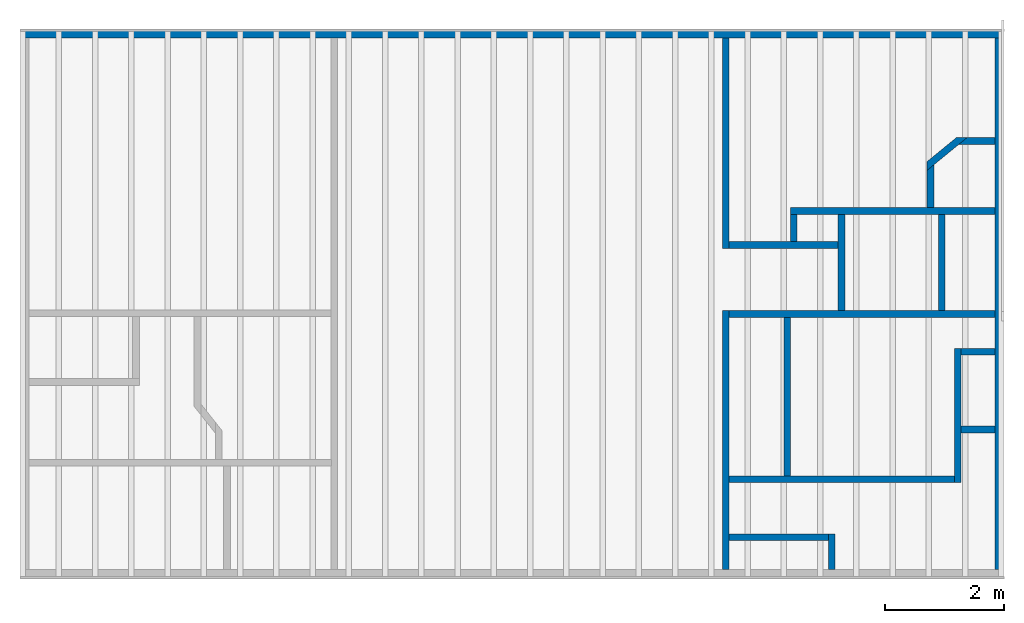
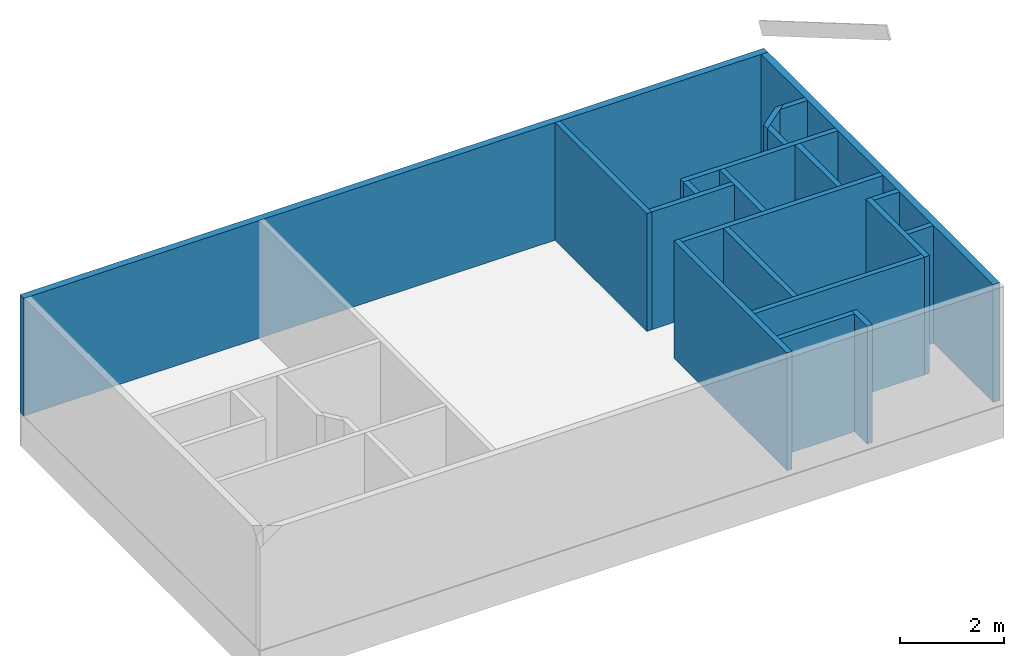
# One storey, part 2 of 2: 20 walls.
"""IFC4 building model written with IfcOpenShell, lengths in inches."""

from ifc_helpers import new_model, entity, si_unit, converted_unit, frame, origin_with_axes, origin_2d_with_axis, place, context, subcontext, project, spatial, indexed_curve, outline, extrude, clip, halfspace, material, layer, layer_set, layer_usage, type_object, element, save


model = new_model("IFC4")

# Units and contexts
model_context = context("Model", 3, precision=1e-05, world=origin_with_axes())
plan_context = context("Plan", 2, precision=1e-05, world=origin_2d_with_axis())
body_context = subcontext(model_context, "Body", "Model", "MODEL_VIEW")
ifc_project = project(units=[converted_unit("PLANEANGLEUNIT", "degree", entity("IfcReal", 0.0174532925199433), si_unit("PLANEANGLEUNIT", "RADIAN"), dimensions=[0, 0, 0, 0, 0, 0, 0]), converted_unit("AREAUNIT", "square inch", entity("IfcReal", 0.0006452), si_unit("AREAUNIT", "SQUARE_METRE"), dimensions=[2, 0, 0, 0, 0, 0, 0]), converted_unit("LENGTHUNIT", "inch", entity("IfcReal", 0.0254), si_unit("LENGTHUNIT", "METRE"), dimensions=[1, 0, 0, 0, 0, 0, 0]), converted_unit("VOLUMEUNIT", "cubic inch", entity("IfcReal", 1.639e-05), si_unit("VOLUMEUNIT", "CUBIC_METRE"), dimensions=[3, 0, 0, 0, 0, 0, 0])], contexts=[model_context, plan_context])

# Site, building, storey
site_placement = place(None, origin_with_axes())
site = spatial("IfcSite", under=ifc_project, at=site_placement)
building_placement = place(site_placement, frame((0.0, 0.0, 109.012492998378), z_axis=(0.0, 0.0, 1.0), x_axis=(1.0, 0.0, 0.0)))
building = spatial("IfcBuilding", under=site, at=building_placement, Name="Building")
storey_placement = place(building_placement, frame((0.0, 0.0, -109.012492998378), z_axis=(0.0, 0.0, 1.0), x_axis=(1.0, 0.0, 0.0)))
storey = spatial("IfcBuildingStorey", under=building, at=storey_placement, Name="1st Floor")

# Walls
ifc_material = material(Name="Default")
ifc_layer_1 = layer(ifc_material, 6.0, Name="6in")
ifc_layer_set_1 = layer_set([ifc_layer_1], Name="6in")
ifc_layer_usage_1 = layer_usage(ifc_layer_set_1, "AXIS2", "POSITIVE", 0.0)
wall_type_1 = type_object("IfcWallType", Name="6in wall", PredefinedType="ELEMENTEDWALL", material=ifc_layer_set_1)
wall_1_placement = place(storey_placement, frame((-18.4998667146277, 0.0, 0.0), z_axis=(0.0, 0.0, 1.0), x_axis=(1.0, 0.0, 0.0)))
element("IfcWall", 1, at=wall_1_placement, inside=storey, type_object=wall_type_1, material=ifc_layer_usage_1, Name="Wall", PredefinedType="NOTDEFINED", context=body_context, shape_type="SweptSolid", body=[
    extrude(outline(indexed_curve([(0.0, 0.0), (0.0, 6.0), (651.499838134765, 6.0), (651.499838134765, 0.0), (0.0, 0.0)], self_intersect=False)), origin_with_axes(), (0.0, 0.0, 1.0), 109.012496948242),
])
ifc_layer_usage_2 = layer_usage(ifc_layer_set_1, "AXIS2", "POSITIVE", 0.0)
wall_2_placement = place(storey_placement, frame((632.999825665331, -351.879014743595, 0.0), z_axis=(0.0, 0.0, 1.0), x_axis=(5.52335052361741e-07, 1.0, 0.0)))
element("IfcWall", 2, at=wall_2_placement, inside=storey, type_object=wall_type_1, material=ifc_layer_usage_2, Name="Wall", PredefinedType="NOTDEFINED", context=body_context, shape_type="SweptSolid", body=[
    extrude(outline(indexed_curve([(0.0, 0.0), (0.0, 6.0), (351.879018305891, 6.0), (351.879018305891, 0.0), (0.0, 0.0)], self_intersect=False)), origin_with_axes(), (0.0, 0.0, 1.0), 109.012496948242),
])
ifc_layer_2 = layer(ifc_material, 4.5, Name="4.5 wall")
ifc_layer_set_2 = layer_set([ifc_layer_2], Name="4.5 wall")
ifc_layer_usage_3 = layer_usage(ifc_layer_set_2, "AXIS2", "POSITIVE", 0.0)
wall_type_2 = type_object("IfcWallType", Name="4.5 in inter stud wall", PredefinedType="ELEMENTEDWALL", material=ifc_layer_set_2)
wall_3_placement = place(storey_placement, frame((446.534532261646, 0.0, 0.0), z_axis=(0.0, 0.0, 1.0), x_axis=(-1.62920684942947e-07, -1.0, 0.0)))
element("IfcWall", 3, at=wall_3_placement, inside=storey, type_object=wall_type_2, material=ifc_layer_usage_3, Name="Wall", PredefinedType="NOTDEFINED", context=body_context, shape_type="SweptSolid", body=[
    extrude(outline(indexed_curve([(0.0, 0.0), (0.0, 4.5), (139.11052940338, 4.5), (139.11052940338, 0.0), (0.0, 0.0)], self_intersect=False)), origin_with_axes(), (0.0, 0.0, 1.0), 109.012496948242),
])
ifc_layer_usage_4 = layer_usage(ifc_layer_set_2, "AXIS2", "POSITIVE", 0.0)
wall_4_placement = place(storey_placement, frame((451.034523370698, -139.110529516626, 0.0), z_axis=(0.0, 0.0, 1.0), x_axis=(1.0, -2.38418579101562e-07, 0.0)))
element("IfcWall", 4, at=wall_4_placement, inside=storey, type_object=wall_type_2, material=ifc_layer_usage_4, Name="Wall", PredefinedType="NOTDEFINED", context=body_context, shape_type="SweptSolid", body=[
    extrude(outline(indexed_curve([(0.0, 0.0), (0.0, 4.5), (72.192170242221, 4.5), (72.192170242221, 0.0), (0.0, 0.0)], self_intersect=False)), origin_with_axes(), (0.0, 0.0, 1.0), 109.012496948242),
])
ifc_layer_usage_5 = layer_usage(ifc_layer_set_2, "AXIS2", "POSITIVE", 0.0)
wall_5_placement = place(storey_placement, frame((496.016111899549, -134.610538407574, 0.0), z_axis=(0.0, 0.0, 1.0), x_axis=(3.13916473260178e-07, 1.0, 0.0)))
element("IfcWall", 5, at=wall_5_placement, inside=storey, type_object=wall_type_2, material=ifc_layer_usage_5, Name="Wall", PredefinedType="NOTDEFINED", context=body_context, shape_type="SweptSolid", body=[
    extrude(outline(indexed_curve([(0.0, 0.0), (0.0, 4.5), (18.03679715968, 4.5), (18.03679715968, 0.0), (0.0, 0.0)], self_intersect=False)), origin_with_axes(), (0.0, 0.0, 1.0), 109.012496948242),
])
ifc_layer_usage_6 = layer_usage(ifc_layer_set_2, "AXIS2", "POSITIVE", 0.0)
wall_6_placement = place(storey_placement, frame((491.516120790497, -116.573731730303, 0.0), z_axis=(0.0, 0.0, 1.0), x_axis=(1.0, -4.76837158203125e-07, 0.0)))
element("IfcWall", 6, at=wall_6_placement, inside=storey, type_object=wall_type_2, material=ifc_layer_usage_6, Name="Wall", PredefinedType="NOTDEFINED", context=body_context, shape_type="SweptSolid", body=[
    extrude(outline(indexed_curve([(0.0, 0.0), (0.0, 4.5), (135.483814515209, 4.5), (135.483814515209, 0.0), (0.0, 0.0)], self_intersect=False)), origin_with_axes(), (0.0, 0.0, 1.0), 109.012496948242),
])
ifc_layer_usage_7 = layer_usage(ifc_layer_set_2, "AXIS2", "POSITIVE", 0.0)
wall_7_placement = place(storey_placement, frame((582.065619821624, -78.0108829182903, 0.0), z_axis=(0.0, 0.0, 1.0), x_axis=(-7.58967132696853e-07, -1.0, 0.0)))
element("IfcWall", 7, at=wall_7_placement, inside=storey, type_object=wall_type_2, material=ifc_layer_usage_7, Name="Wall", PredefinedType="NOTDEFINED", context=body_context, shape_type="Clipping", body=[
    clip(extrude(outline(indexed_curve([(0.0, 0.0), (0.0, 4.5), (34.062895801055, 4.5), (34.062895801055, 0.0), (0.0, 0.0)], self_intersect=False)), origin_with_axes(), (0.0, 0.0, 1.0), 109.012496948242), halfspace(frame((9.49567403849654, 2.88683644268574e-05, 0.0), z_axis=(-0.316489070653915, -0.258926063776016, 0.0), x_axis=(-0.0935116708278656, 0.114300653338432, 0.0)), False)),
])
ifc_layer_usage_8 = layer_usage(ifc_layer_set_2, "AXIS2", "POSITIVE", 0.0)
wall_8_placement = place(storey_placement, frame((605.672062851313, -62.3794521872453, 0.0), z_axis=(0.0, 0.0, 1.0), x_axis=(-0.773979425430298, -0.633210778236389, 0.0)))
element("IfcWall", 8, at=wall_8_placement, inside=storey, type_object=wall_type_2, material=ifc_layer_usage_8, Name="Wall", PredefinedType="NOTDEFINED", context=body_context, shape_type="Clipping", body=[
    clip(clip(extrude(outline(indexed_curve([(0.0, 0.0), (0.0, 4.5), (34.1816707620317, 4.5), (34.1816707620317, 0.0), (0.0, 0.0)], self_intersect=False)), origin_with_axes(), (0.0, 0.0, 1.0), 109.012496948242), halfspace(frame((5.50004910296343, 5.16260702778974e-05, -109.012502384937), z_axis=(-0.316488713026047, -0.386823624372482, 0.0), x_axis=(-0.139702126383781, 0.114300526678562, 0.0)), False)), halfspace(frame((30.5000628073384, 9.38655823234498e-06, -109.012502384937), z_axis=(0.316490888595581, -0.258928626775742, 0.0), x_axis=(0.0935125946998596, 0.114301316440105, 0.0)), False)),
])
ifc_layer_usage_9 = layer_usage(ifc_layer_set_2, "AXIS2", "POSITIVE", 0.0)
wall_9_placement = place(storey_placement, frame((627.000388198011, -65.8629259725255, 0.0), z_axis=(0.0, 0.0, 1.0), x_axis=(-1.0, 2.94764813588699e-05, 0.0)))
element("IfcWall", 9, at=wall_9_placement, inside=storey, type_object=wall_type_2, material=ifc_layer_usage_9, Name="Wall", PredefinedType="NOTDEFINED", context=body_context, shape_type="Clipping", body=[
    clip(extrude(outline(indexed_curve([(0.0, 0.0), (0.0, 4.5), (31.0853525906906, 4.5), (31.0853525906906, 0.0), (0.0, 0.0)], self_intersect=False)), origin_with_axes(), (0.0, 0.0, 1.0), 109.012496948242), halfspace(frame((18.4789147433334, 3.10517246211608e-06, 0.0), z_axis=(0.31648713350296, -0.386821448802948, 0.0), x_axis=(0.139701336622238, 0.114299960434437, 0.0)), False)),
])
ifc_layer_usage_10 = layer_usage(ifc_layer_set_2, "AXIS2", "POSITIVE", 0.0)
wall_10_placement = place(storey_placement, frame((523.226692920595, -116.57375050342, 0.0), z_axis=(0.0, 0.0, 1.0), x_axis=(-2.82129974493728e-07, -1.0, 0.0)))
element("IfcWall", 10, at=wall_10_placement, inside=storey, type_object=wall_type_2, material=ifc_layer_usage_10, Name="Wall", PredefinedType="NOTDEFINED", context=body_context, shape_type="SweptSolid", body=[
    extrude(outline(indexed_curve([(0.0, 0.0), (0.0, 4.5), (63.7524908074572, 4.5), (63.7524908074572, 0.0), (0.0, 0.0)], self_intersect=False)), origin_with_axes(), (0.0, 0.0, 1.0), 109.012496948242),
])
ifc_layer_usage_11 = layer_usage(ifc_layer_set_2, "AXIS2", "POSITIVE", 0.0)
wall_11_placement = place(storey_placement, frame((626.999937643216, -180.326315361684, 0.0), z_axis=(0.0, 0.0, 1.0), x_axis=(-1.0, 6.27832946520357e-07, 0.0)))
element("IfcWall", 11, at=wall_11_placement, inside=storey, type_object=wall_type_2, material=ifc_layer_usage_11, Name="Wall", PredefinedType="NOTDEFINED", context=body_context, shape_type="SweptSolid", body=[
    extrude(outline(indexed_curve([(0.0, 0.0), (0.0, 4.5), (176.311028354232, 4.5), (176.311028354232, 0.0), (0.0, 0.0)], self_intersect=False)), origin_with_axes(), (0.0, 0.0, 1.0), 109.012496948242),
])
ifc_layer_usage_12 = layer_usage(ifc_layer_set_2, "AXIS2", "POSITIVE", 0.0)
wall_12_placement = place(storey_placement, frame((516.737126928615, -328.200182576818, 0.0), z_axis=(0.0, 0.0, 1.0), x_axis=(-1.0, 1.10467010472348e-06, 0.0)))
element("IfcWall", 12, at=wall_12_placement, inside=storey, type_object=wall_type_2, material=ifc_layer_usage_12, Name="Wall", PredefinedType="NOTDEFINED", context=body_context, shape_type="SweptSolid", body=[
    extrude(outline(indexed_curve([(0.0, 0.0), (0.0, 4.5), (65.7028665662729, 4.5), (65.7028665662729, 0.0), (0.0, 0.0)], self_intersect=False)), origin_with_axes(), (0.0, 0.0, 1.0), 109.012496948242),
])
ifc_layer_usage_13 = layer_usage(ifc_layer_set_2, "AXIS2", "POSITIVE", 0.0)
wall_13_placement = place(storey_placement, frame((516.737126928615, -328.200182576818, 0.0), z_axis=(0.0, 0.0, 1.0), x_axis=(-1.11659494450578e-06, -1.0, 0.0)))
element("IfcWall", 13, at=wall_13_placement, inside=storey, type_object=wall_type_2, material=ifc_layer_usage_13, Name="Wall", PredefinedType="NOTDEFINED", context=body_context, shape_type="SweptSolid", body=[
    extrude(outline(indexed_curve([(0.0, 0.0), (0.0, 4.5), (23.6787565866284, 4.5), (23.6787565866284, 0.0), (0.0, 0.0)], self_intersect=False)), origin_with_axes(), (0.0, 0.0, 1.0), 109.012496948242),
])
ifc_layer_usage_14 = layer_usage(ifc_layer_set_2, "AXIS2", "POSITIVE", 0.0)
wall_14_placement = place(storey_placement, frame((491.724840299351, -289.769867273766, 0.0), z_axis=(0.0, 0.0, 1.0), x_axis=(9.09962921014085e-07, 1.0, 0.0)))
element("IfcWall", 14, at=wall_14_placement, inside=storey, type_object=wall_type_2, material=ifc_layer_usage_14, Name="Wall", PredefinedType="NOTDEFINED", context=body_context, shape_type="SweptSolid", body=[
    extrude(outline(indexed_curve([(0.0, 0.0), (0.0, 4.5), (104.943653593398, 4.5), (104.943653593398, 0.0), (0.0, 0.0)], self_intersect=False)), origin_with_axes(), (0.0, 0.0, 1.0), 109.012496948242),
])
ifc_layer_usage_15 = layer_usage(ifc_layer_set_2, "AXIS2", "POSITIVE", 0.0)
wall_15_placement = place(storey_placement, frame((600.110602191114, -289.769867273766, 0.0), z_axis=(0.0, 0.0, 1.0), x_axis=(-1.0, 1.50995802528087e-07, 0.0)))
element("IfcWall", 15, at=wall_15_placement, inside=storey, type_object=wall_type_2, material=ifc_layer_usage_15, Name="Wall", PredefinedType="NOTDEFINED", context=body_context, shape_type="SweptSolid", body=[
    extrude(outline(indexed_curve([(0.0, 0.0), (0.0, 4.5), (149.076267483299, 4.5), (149.076267483299, 0.0), (0.0, 0.0)], self_intersect=False)), origin_with_axes(), (0.0, 0.0, 1.0), 109.012496948242),
])
ifc_layer_usage_16 = layer_usage(ifc_layer_set_2, "AXIS2", "POSITIVE", 0.0)
wall_16_placement = place(storey_placement, frame((600.110602191114, -205.395822449932, 0.0), z_axis=(0.0, 0.0, 1.0), x_axis=(-2.82129974493728e-07, -1.0, 0.0)))
element("IfcWall", 16, at=wall_16_placement, inside=storey, type_object=wall_type_2, material=ifc_layer_usage_16, Name="Wall", PredefinedType="NOTDEFINED", context=body_context, shape_type="SweptSolid", body=[
    extrude(outline(indexed_curve([(0.0, 0.0), (0.0, 4.5), (88.6997107265308, 4.5), (88.6997107265308, 0.0), (0.0, 0.0)], self_intersect=False)), origin_with_axes(), (0.0, 0.0, 1.0), 109.012496948242),
])
ifc_layer_usage_17 = layer_usage(ifc_layer_set_2, "AXIS2", "POSITIVE", 0.0)
wall_17_placement = place(storey_placement, frame((626.999900096983, -205.395841223048, 0.0), z_axis=(0.0, 0.0, 1.0), x_axis=(-1.0, 6.27832946520357e-07, 0.0)))
element("IfcWall", 17, at=wall_17_placement, inside=storey, type_object=wall_type_2, material=ifc_layer_usage_17, Name="Wall", PredefinedType="NOTDEFINED", context=body_context, shape_type="SweptSolid", body=[
    extrude(outline(indexed_curve([(0.0, 0.0), (0.0, 4.5), (22.389306789238, 4.5), (22.389306789238, 0.0), (0.0, 0.0)], self_intersect=False)), origin_with_axes(), (0.0, 0.0, 1.0), 109.012496948242),
])
ifc_layer_usage_18 = layer_usage(ifc_layer_set_2, "AXIS2", "POSITIVE", 0.0)
wall_18_placement = place(storey_placement, frame((604.610593300166, -261.386736171452, 0.0), z_axis=(0.0, 0.0, 1.0), x_axis=(1.0, -4.76837158203125e-07, 0.0)))
element("IfcWall", 18, at=wall_18_placement, inside=storey, type_object=wall_type_2, material=ifc_layer_usage_18, Name="Wall", PredefinedType="NOTDEFINED", context=body_context, shape_type="SweptSolid", body=[
    extrude(outline(indexed_curve([(0.0, 0.0), (0.0, 4.5), (22.389306789238, 4.5), (22.389306789238, 0.0), (0.0, 0.0)], self_intersect=False)), origin_with_axes(), (0.0, 0.0, 1.0), 109.012496948242),
])
ifc_layer_usage_19 = layer_usage(ifc_layer_set_2, "AXIS2", "POSITIVE", 0.0)
wall_19_placement = place(storey_placement, frame((589.5066824485, -116.573778663095, 0.0), z_axis=(0.0, 0.0, 1.0), x_axis=(-5.2054855359529e-07, -1.0, 0.0)))
element("IfcWall", 19, at=wall_19_placement, inside=storey, type_object=wall_type_2, material=ifc_layer_usage_19, Name="Wall", PredefinedType="NOTDEFINED", context=body_context, shape_type="SweptSolid", body=[
    extrude(outline(indexed_curve([(0.0, 0.0), (0.0, 4.5), (63.7525168922823, 4.5), (63.7525168922823, 0.0), (0.0, 0.0)], self_intersect=False)), origin_with_axes(), (0.0, 0.0, 1.0), 109.012496948242),
])
ifc_layer_usage_20 = layer_usage(ifc_layer_set_2, "AXIS2", "POSITIVE", 0.0)
wall_20_placement = place(storey_placement, frame((451.034260547067, -351.879089836061, 0.0), z_axis=(0.0, 0.0, 1.0), x_axis=(9.09962921014085e-07, 1.0, 0.0)))
element("IfcWall", 20, at=wall_20_placement, inside=storey, type_object=wall_type_2, material=ifc_layer_usage_20, Name="Wall", PredefinedType="NOTDEFINED", context=body_context, shape_type="SweptSolid", body=[
    extrude(outline(indexed_curve([(0.0, 0.0), (0.0, 4.5), (171.552886749269, 4.5), (171.552886749269, 0.0), (0.0, 0.0)], self_intersect=False)), origin_with_axes(), (0.0, 0.0, 1.0), 109.012496948242),
])

save(model, "model.ifc")
